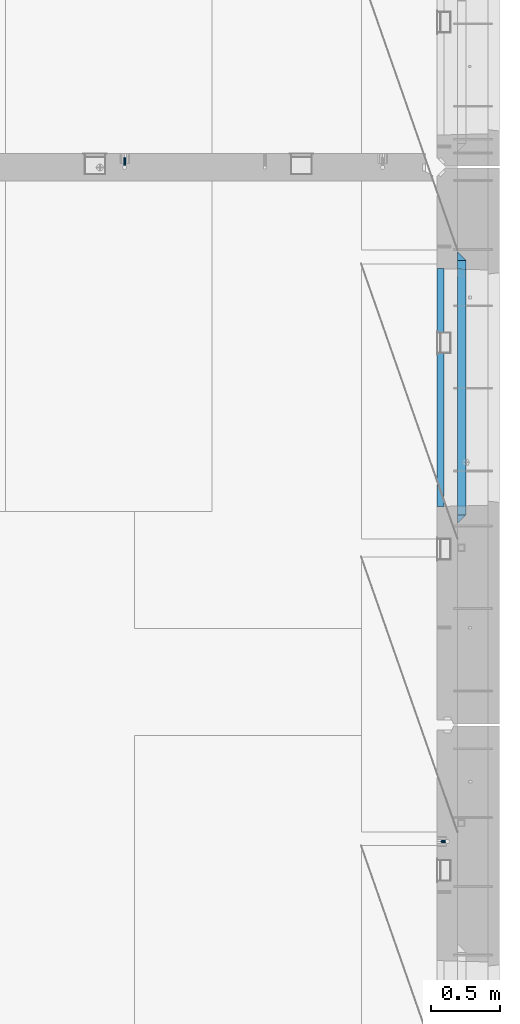
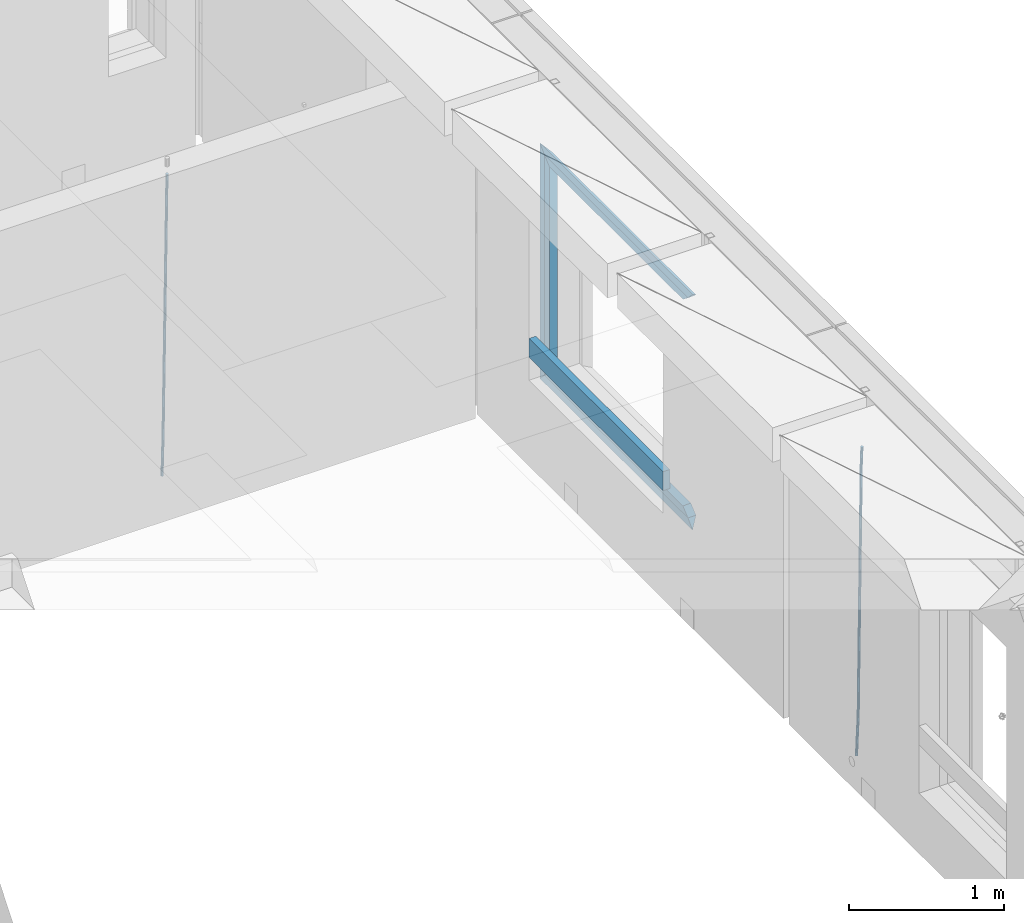
# One storey, part 127 of 341: 9 beams, 3 elements without a shape of their own.
"""IFC2X3 building model written with IfcOpenShell, lengths in millimetres."""

from ifc_helpers import new_model, si_unit, frame, origin_with_axes, place, context, subcontext, project, spatial, faceted_brep, material, type_object, element, aggregate, save


model = new_model("IFC2X3")

# Units and contexts
model_context = context("Model", 3, precision=1e-05, world=origin_with_axes())
body_context = subcontext(model_context, "Body", "Model", "MODEL_VIEW")
ifc_project = project(units=[si_unit("LENGTHUNIT", "METRE", prefix="MILLI"), si_unit("AREAUNIT", "SQUARE_METRE"), si_unit("VOLUMEUNIT", "CUBIC_METRE"), si_unit("MASSUNIT", "GRAM", prefix="KILO"), si_unit("TIMEUNIT", "SECOND"), si_unit("PLANEANGLEUNIT", "RADIAN"), si_unit("SOLIDANGLEUNIT", "STERADIAN"), si_unit("THERMODYNAMICTEMPERATUREUNIT", "DEGREE_CELSIUS"), si_unit("LUMINOUSINTENSITYUNIT", "LUMEN")], contexts=[model_context])

# Site, building, storey
site_placement = place(None, origin_with_axes())
site = spatial("IfcSite", under=ifc_project, at=site_placement, CompositionType="ELEMENT")
building_placement = place(site_placement, origin_with_axes())
building = spatial("IfcBuilding", under=site, at=building_placement, CompositionType="ELEMENT")
storey_placement = place(building_placement, origin_with_axes())
storey = spatial("IfcBuildingStorey", under=building, at=storey_placement, Name="5", CompositionType="ELEMENT", Elevation=0.0)

# Assembly, beam
assembly_1_placement = place(storey_placement, origin_with_axes())
assembly_1 = element("IfcElementAssembly", 1, at=assembly_1_placement, inside=storey, AssemblyPlace="NOTDEFINED", PredefinedType="REINFORCEMENT_UNIT")
ifc_material_1 = material()
beam_type_1 = type_object("IfcBeamType", Name="D20", PredefinedType="NOTDEFINED")
beam_1_placement = place(assembly_1_placement, frame((32639.9999999961, 17044.9997581385, 93990.0), z_axis=(0.00020576299992186, -0.999642804629538, -0.0267249099901004), x_axis=(-4.30000201928125e-08, -0.0267249099948059, 0.999642825806181)))
beam_1 = element("IfcBeam", 2, at=beam_1_placement, type_object=beam_type_1, material=ifc_material_1, Name="JM20", ObjectType="D20", context=body_context, shape_type="Brep", body=[
    faceted_brep([(0.0, -10.0, 0.0), (-4.19531716033816e-08, -7.07106781186667, -7.07106781187031), (60.4266690400545, -7.0710677960451, -7.07106780570757), (60.4266690441291, -9.99999998418934, 6.15546014159918e-09), (0.0, 0.0, -10.0), (60.426669036824, 1.58106558956206e-08, -9.99999999384454), (4.196772351861e-08, 7.07106781186303, -7.07106781186667), (60.4266690363438, 7.07106782768096, -7.07106780570757), (0.0, 10.0, 0.0), (60.4266690388904, 10.0000000158179, 6.15182216279209e-09), (4.196772351861e-08, 7.07106781185939, 7.07106781185939), (60.4266690429649, 7.07106782768096, 7.07106781802577), (0.0, 0.0, 10.0), (60.4266690461809, 1.58179318532348e-08, 10.0000000061555), (-4.19531716033816e-08, -7.07106781187031, 7.07106781185939), (60.4266690466611, -7.07106779605238, 7.07106781802213), (61.0378400410118, -7.07106779588503, -7.07106780564936), (60.991799419251, -9.99999998403655, 6.21366780251265e-09), (61.0569027789461, 1.5985278878361e-08, -9.99999999378269), (61.0378209396877, 7.07106782784831, -7.07106780564936), (60.9917724058905, 10.0000000159635, 6.21366780251265e-09), (60.9457317841297, 7.07106782781193, 7.0710678180767), (60.9266690461809, 1.59488990902901e-08, 10.0000000062028), (60.9457508854539, -7.07106779591413, 7.0710678180767), (61.6489592143771, -7.07106614513759, -7.06310863441468), (61.5568818710308, -9.9999984576425, 0.00735959856683621), (61.6870830769039, 1.71821739058942e-06, -9.99179257185824), (61.6489210170112, 7.07106947854481, -7.06310888312146), (61.556827851804, 10.0000015422847, 0.00735924683976918), (61.4647505084577, 7.07106922979438, 7.07782747982128), (61.4266266459163, 1.36643211590126e-06, 10.0065114172685), (61.464788705809, -7.07106639389531, 7.07782772852806), (176.543135720174, -7.07075579406956, -5.56673531796696), (176.451058376813, -9.99968810657447, 1.50373291501455), (176.581259582701, 0.000312069292704109, -8.49541925541052), (176.543097522794, 7.07137982961285, -5.56673556667374), (176.451004357587, 10.00031189336, 1.50373256329476), (176.35892701424, 7.07137958085514, 8.57420079627263), (176.320803151699, 0.000311717507429421, 11.5028847337162), (176.358965211621, -7.07075604281999, 8.57420104497578), (177.098753836006, -7.07075429323595, -5.55949898843028), (176.98362511232, -9.99968666800123, 1.510669025065), (177.146421932586, 0.000313595905026887, -8.48805862247536), (177.098706077581, 7.07138133041735, -5.55949936166144), (176.983557571715, 10.0003133318824, 1.51066849724157), (176.868428848029, 7.07138095712435, 8.58083651073321), (176.820760751449, 0.000313067976094317, 11.5093961447819), (176.868476606425, -7.07075466652896, 8.58083688396073), (177.654312950661, -7.07075204110879, -5.54863964998367), (177.516135294456, -9.99968450931192, 1.52107783331303), (177.711524267797, 0.000315886711177882, -8.47701274570863), (177.654255632195, 7.07138358250813, -5.54864021007961), (177.516054233929, 10.0003154905207, 1.5210770412159), (177.377876577739, 7.0713830223176, 8.59079452451624), (177.320665260588, 0.000315094497636892, 11.5191676202448), (177.377933896176, -7.07075260129932, 8.59079508461218), (299.499456785634, -7.07025810522464, -3.16697112782276), (299.361279129444, -9.99919057342777, 3.90274635547394), (299.556668102785, 0.000809822595329024, -6.09534422354773), (299.499399467197, 7.07187751838501, -3.1669716879187), (299.361198068917, 10.0008094264049, 3.90274556338045), (299.223020412712, 7.07187695819448, 10.9724630466735), (299.165809095575, 0.000809030381788034, 13.9008361423985), (299.223077731163, -7.07025866542244, 10.9724636067695), (300.03174732349, -7.07025594743027, -3.15656661289177), (299.971788958996, -9.99918809853989, 3.91467979818117), (300.056572611924, 0.000811849109595641, -6.08557274808481), (300.031722507032, 7.07187967631762, -3.15656653768019), (299.971753863239, 10.0008119014747, 3.91467990454839), (299.91179549876, 7.07187975035777, 10.9859263156177), (299.886970210311, 0.000811953817901667, 13.9149324508144), (299.911820315203, -7.0702558733974, 10.9859262404061), (300.564137759997, -7.07025623699155, -3.15794273276697), (300.582413367199, -9.99918843065097, 3.91310145956595), (300.556570941641, 0.000811577163403854, -6.0868651410201), (300.564145451674, 7.07187938674906, -3.15794274158179), (300.582424244858, 10.0008115693345, 3.91310144710224), (300.600699852032, 7.07187937566778, 10.9841456394352), (300.608266670402, 0.000811561512819026, 13.9130680476919), (300.600692160384, -7.07025624805829, 10.98414564825), (2294.16589219622, -7.0713405251372, -8.31099358700158), (2294.1841678034, -10.0002727187966, -1.23994939466866), (2294.15832537785, -0.000272710982244462, -11.2399159952547), (2294.16589988787, 7.07079509858886, -8.31099359582004), (2294.18417868105, 9.99972728118883, -1.23994940713601), (2294.20245428824, 7.07079508752213, 5.83109478519327), (2294.2100211066, -0.00027272663282929, 8.76001719345368), (2294.20244659658, -7.07134053620393, 5.83109479401173), (2294.7782683276, -7.07134085819416, -8.31257645345977), (2294.72126025338, -10.000273010919, -1.24133766827799), (2294.84007459224, -0.000273081772320438, -11.2416781768807), (2294.87047377572, 7.07079471537872, -8.31281477453012), (2294.85165844864, 9.9997269181622, -1.24167470516841), (2294.7946503744, 7.07079476544459, 5.82956408001337), (2294.73284410976, -0.000273010977252852, 8.75866580342336), (2294.7024449263, -7.07134080815013, 5.82980240107645), (2295.39054023061, -7.0793250091956, -8.30442771922026), (2295.25826128852, -10.0072756143927, -1.23419071494573), (2295.52170777075, -0.00916171800054144, -11.2326063125765), (2295.57492774284, 7.06160849139269, -8.30343918807193), (2295.51902460904, 9.99102432676591, -1.23279272078435), (2295.38674566693, 7.06307372157607, 5.83744428349019), (2295.25557812679, -0.0070895696117077, 8.76562287684646), (2295.20235815471, -7.07785977901949, 5.83645575234186), (2317.1947101649, -7.36365585014573, -8.01423575520312), (2317.06243122277, -10.2916064553428, -0.94399875092131), (2317.32587770502, -0.293492558957951, -10.9424143485521), (2317.37909767711, 6.77727765044983, -8.01324722405116), (2317.32319454331, 9.70669348581578, -0.942600756767206), (2317.1909156012, 6.77874288063322, 6.12763624751096), (2317.05974806109, -0.291420410569117, 9.0558148408636), (2317.00652808898, -7.36219061996962, 6.12664771636264), (2317.83015404257, -7.37194216843636, -8.00577862486898), (2317.72252095213, -10.300214160583, -0.935213608652703), (2317.90419832576, -0.301033978277701, -10.9347174723516), (2317.90127966482, 6.77046829039318, -8.00629749759901), (2317.82310777172, 9.70017451494641, -0.935947405505431), (2317.71547468127, 6.77190252279979, 6.13461761071085), (2317.64143039809, -0.29900566735887, 9.06355645819713), (2317.64434905903, -7.37050793602975, 6.13513648344451), (2318.46565174212, -7.3700661537805, -7.99751648408346), (2318.38266643914, -10.2982456018653, -0.926623872735945), (2318.48256818345, -0.299336209594912, -10.9272153854981), (2318.42350634121, 6.77200652527245, -7.99954269419686), (2318.32306384158, 9.70166538090416, -0.929489366557391), (2318.2400785386, 6.77348593281204, 6.14140324480104), (2318.22316209726, -0.297244011366274, 9.07110214621207), (2318.2822239395, -7.36858674623363, 6.1434294549108), (2418.48643733139, -7.07180401323421, -6.70013846199799), (2418.4034520284, -9.99998346132634, 0.370754149349523), (2418.5033537727, -0.00107406904135132, -9.62983736341266), (2418.44429193046, 7.07026866581873, -6.70216467211139), (2418.34384943081, 9.99992752145772, 0.367888655531715), (2418.26086412782, 7.0717480733656, 7.43878126688651), (2418.24394768651, 0.00101812917273492, 10.3684801682975), (2418.30300952874, -7.07032460568735, 7.44080747699627)], [[[0, 1, 2, 3]], [[1, 4, 5, 2]], [[4, 6, 7, 5]], [[6, 8, 9, 7]], [[8, 10, 11, 9]], [[10, 12, 13, 11]], [[12, 14, 15, 13]], [[14, 0, 3, 15]], [[14, 12, 10, 8, 6, 4, 1, 0]], [[3, 2, 16, 17]], [[2, 5, 18, 16]], [[5, 7, 19, 18]], [[7, 9, 20, 19]], [[9, 11, 21, 20]], [[11, 13, 22, 21]], [[13, 15, 23, 22]], [[15, 3, 17, 23]], [[17, 16, 24, 25]], [[16, 18, 26, 24]], [[18, 19, 27, 26]], [[19, 20, 28, 27]], [[20, 21, 29, 28]], [[21, 22, 30, 29]], [[22, 23, 31, 30]], [[23, 17, 25, 31]], [[25, 24, 32, 33]], [[24, 26, 34, 32]], [[26, 27, 35, 34]], [[27, 28, 36, 35]], [[28, 29, 37, 36]], [[29, 30, 38, 37]], [[30, 31, 39, 38]], [[31, 25, 33, 39]], [[33, 32, 40, 41]], [[32, 34, 42, 40]], [[34, 35, 43, 42]], [[35, 36, 44, 43]], [[36, 37, 45, 44]], [[37, 38, 46, 45]], [[38, 39, 47, 46]], [[39, 33, 41, 47]], [[41, 40, 48, 49]], [[40, 42, 50, 48]], [[42, 43, 51, 50]], [[43, 44, 52, 51]], [[44, 45, 53, 52]], [[45, 46, 54, 53]], [[46, 47, 55, 54]], [[47, 41, 49, 55]], [[49, 48, 56, 57]], [[48, 50, 58, 56]], [[50, 51, 59, 58]], [[51, 52, 60, 59]], [[52, 53, 61, 60]], [[53, 54, 62, 61]], [[54, 55, 63, 62]], [[55, 49, 57, 63]], [[57, 56, 64, 65]], [[56, 58, 66, 64]], [[58, 59, 67, 66]], [[59, 60, 68, 67]], [[60, 61, 69, 68]], [[61, 62, 70, 69]], [[62, 63, 71, 70]], [[63, 57, 65, 71]], [[65, 64, 72, 73]], [[64, 66, 74, 72]], [[66, 67, 75, 74]], [[67, 68, 76, 75]], [[68, 69, 77, 76]], [[69, 70, 78, 77]], [[70, 71, 79, 78]], [[71, 65, 73, 79]], [[73, 72, 80, 81]], [[72, 74, 82, 80]], [[74, 75, 83, 82]], [[75, 76, 84, 83]], [[76, 77, 85, 84]], [[77, 78, 86, 85]], [[78, 79, 87, 86]], [[79, 73, 81, 87]], [[81, 80, 88, 89]], [[80, 82, 90, 88]], [[82, 83, 91, 90]], [[83, 84, 92, 91]], [[84, 85, 93, 92]], [[85, 86, 94, 93]], [[86, 87, 95, 94]], [[87, 81, 89, 95]], [[89, 88, 96, 97]], [[88, 90, 98, 96]], [[90, 91, 99, 98]], [[91, 92, 100, 99]], [[92, 93, 101, 100]], [[93, 94, 102, 101]], [[94, 95, 103, 102]], [[95, 89, 97, 103]], [[97, 96, 104, 105]], [[96, 98, 106, 104]], [[98, 99, 107, 106]], [[99, 100, 108, 107]], [[100, 101, 109, 108]], [[101, 102, 110, 109]], [[102, 103, 111, 110]], [[103, 97, 105, 111]], [[105, 104, 112, 113]], [[104, 106, 114, 112]], [[106, 107, 115, 114]], [[107, 108, 116, 115]], [[108, 109, 117, 116]], [[109, 110, 118, 117]], [[110, 111, 119, 118]], [[111, 105, 113, 119]], [[113, 112, 120, 121]], [[112, 114, 122, 120]], [[114, 115, 123, 122]], [[115, 116, 124, 123]], [[116, 117, 125, 124]], [[117, 118, 126, 125]], [[118, 119, 127, 126]], [[119, 113, 121, 127]], [[121, 120, 128, 129]], [[120, 122, 130, 128]], [[122, 123, 131, 130]], [[123, 124, 132, 131]], [[124, 125, 133, 132]], [[125, 126, 134, 133]], [[126, 127, 135, 134]], [[127, 121, 129, 135]], [[130, 131, 132, 133, 134, 135, 129, 128]]]),
])
aggregate(assembly_1, [beam_1])

assembly_2_placement = place(storey_placement, origin_with_axes())
assembly_2 = element("IfcElementAssembly", 3, at=assembly_2_placement, inside=storey, AssemblyPlace="NOTDEFINED", PredefinedType="REINFORCEMENT_UNIT")
beam_2_placement = place(assembly_2_placement, frame((34944.9999977209, 12080.9402860984, 93990.0), z_axis=(0.999642804629538, 0.000205762999925497, -0.0267249099901003), x_axis=(0.0267249109941254, -4.30000210532798e-08, 0.999642825779465)))
beam_2 = element("IfcBeam", 4, at=beam_2_placement, type_object=beam_type_1, material=ifc_material_1, Name="JM20", ObjectType="D20", context=body_context, shape_type="Brep", body=[
    faceted_brep([(0.0, -10.0, 0.0), (-4.19531716033816e-08, -7.07106781186667, -7.07106781187031), (60.4266690400545, -7.0710677960451, -7.07106780570757), (60.4266690441291, -9.99999998418934, 6.15546014159918e-09), (0.0, 0.0, -10.0), (60.426669036824, 1.58106558956206e-08, -9.99999999384454), (4.196772351861e-08, 7.07106781186303, -7.07106781186667), (60.4266690363438, 7.07106782768096, -7.07106780570757), (0.0, 10.0, 0.0), (60.4266690388904, 10.0000000158179, 6.15182216279209e-09), (4.196772351861e-08, 7.07106781185939, 7.07106781185939), (60.4266690429649, 7.07106782768096, 7.07106781802577), (0.0, 0.0, 10.0), (60.4266690461809, 1.58179318532348e-08, 10.0000000061555), (-4.19531716033816e-08, -7.07106781187031, 7.07106781185939), (60.4266690466611, -7.07106779605238, 7.07106781802213), (61.0378400410118, -7.07106779588503, -7.07106780564936), (60.991799419251, -9.99999998403655, 6.21366780251265e-09), (61.0569027789461, 1.5985278878361e-08, -9.99999999378269), (61.0378209396877, 7.07106782784831, -7.07106780564936), (60.9917724058905, 10.0000000159635, 6.21366780251265e-09), (60.9457317841297, 7.07106782781193, 7.0710678180767), (60.9266690461809, 1.59488990902901e-08, 10.0000000062028), (60.9457508854539, -7.07106779591413, 7.0710678180767), (61.6489592143771, -7.07106614513759, -7.06310863441468), (61.5568818710308, -9.9999984576425, 0.00735959856683621), (61.6870830769039, 1.71821739058942e-06, -9.99179257185824), (61.6489210170112, 7.07106947854481, -7.06310888312146), (61.556827851804, 10.0000015422847, 0.00735924683976918), (61.4647505084577, 7.07106922979438, 7.07782747982128), (61.4266266459163, 1.36643211590126e-06, 10.0065114172685), (61.464788705809, -7.07106639389531, 7.07782772852806), (176.543135720174, -7.07075579406956, -5.56673531796696), (176.451058376813, -9.99968810657447, 1.50373291501455), (176.581259582701, 0.000312069292704109, -8.49541925541052), (176.543097522794, 7.07137982961285, -5.56673556667374), (176.451004357587, 10.00031189336, 1.50373256329476), (176.35892701424, 7.07137958085514, 8.57420079627263), (176.320803151699, 0.000311717507429421, 11.5028847337162), (176.358965211621, -7.07075604281999, 8.57420104497578), (177.098753836006, -7.07075429323595, -5.55949898843028), (176.98362511232, -9.99968666800123, 1.510669025065), (177.146421932586, 0.000313595905026887, -8.48805862247536), (177.098706077581, 7.07138133041735, -5.55949936166144), (176.983557571715, 10.0003133318824, 1.51066849724157), (176.868428848029, 7.07138095712435, 8.58083651073321), (176.820760751449, 0.000313067976094317, 11.5093961447819), (176.868476606425, -7.07075466652896, 8.58083688396073), (177.654312950661, -7.07075204110879, -5.54863964998367), (177.516135294456, -9.99968450931192, 1.52107783331303), (177.711524267797, 0.000315886711177882, -8.47701274570863), (177.654255632195, 7.07138358250813, -5.54864021007961), (177.516054233929, 10.0003154905207, 1.5210770412159), (177.377876577739, 7.0713830223176, 8.59079452451624), (177.320665260588, 0.000315094497636892, 11.5191676202448), (177.377933896176, -7.07075260129932, 8.59079508461218), (299.436796249574, -7.07025836271714, -3.1681962331204), (299.298618593355, -9.99919083092027, 3.90152125031091), (299.494007566798, 0.000809565110102994, -6.09656932889993), (299.436738931283, 7.07187726089978, -3.16819679320906), (299.298537533061, 10.0008091689197, 3.90152045822106), (299.160359876842, 7.07187670072017, 10.9712379416487), (299.103148559603, 0.000808772889286047, 13.8996110374392), (299.160417195119, -7.07025892290039, 10.9712385017483), (299.98743051647, -7.07025613056248, -3.15743315966392), (299.971788958996, -9.99918809853989, 3.91467979818117), (299.993912075952, 0.000811591617093654, -6.08679785393178), (299.987423933868, 7.07187949325817, -3.1574327280432), (299.971753863239, 10.0008119014747, 3.91467990454839), (299.95611230444, 7.07187992653053, 10.9867922621015), (299.949630744944, 0.000812204350950196, 13.9161569563694), (299.956118887014, -7.07025569729012, 10.9867918304735), (300.538107039494, -7.07025785017686, -3.16575821840888), (300.644985195438, -9.99919020432935, 3.90450175465594), (300.493854948218, 0.000810030429420294, -6.09435592770024), (300.538151196495, 7.071877773491, -3.16575855385963), (300.645047642858, 10.0008097955724, 3.90450128024895), (300.751925798773, 7.07187744142357, 10.9747612533101), (300.796177890064, 0.000809560813650023, 13.9033589625978), (300.751881641787, -7.07025818224065, 10.9747615887682), (2293.36490490142, -7.07648090940347, -33.2930642912361), (2293.47178305736, -10.0054132635523, -26.2228043181785), (2293.32065281013, -0.00541302880083094, -36.2216620005347), (2293.36494905842, 7.06565471425711, -33.2930646266868), (2293.47184550477, 9.99458673634581, -26.2228047925819), (2293.57872366071, 7.06565438219332, -19.1525448195243), (2293.62297575199, -0.00541349841296324, -16.2239471102366), (2293.57867950371, -7.0764812414709, -19.1525444840736), (2294.0658245362, -7.07648309818615, -33.3036607065333), (2294.05312277409, -10.0054150789219, -26.2315929392535), (2294.10928714235, -0.00541549149056664, -36.2335844756526), (2294.15805078732, 7.06565223761572, -33.3050546393533), (2294.18355038921, 9.99458451388637, -26.2335642579346), (2294.17084862708, 7.06565253314329, -19.1614964906439), (2294.12738602093, -0.00541507354500936, -16.2315727215355), (2294.07862237596, -7.07648280265857, -19.1601025578348), (2294.76670261032, -7.08562269121467, -33.294332712383), (2294.63442802057, -10.0129954178956, -26.2238563411993), (2294.89787471293, -0.0156988342423574, -36.2230891548279), (2294.95110548967, 7.05531064255774, -33.2944998654275), (2294.89521307347, 9.98530428734011, -26.2240927312887), (2294.76293848372, 7.0579315606592, -19.1536163601049), (2294.63176638114, -0.0119922963167483, -16.2248599176673), (2294.57853560438, -7.08300177311321, -19.1534492070678), (2316.52657204497, -7.36937582653991, -33.0047303660212), (2316.39429745522, -10.2967485532172, -25.9342539948302), (2316.65774414754, -0.299451969567599, -35.9334868084661), (2316.7109749243, 6.7715575072325, -33.0048975190657), (2316.65508250811, 9.70155115201487, -25.9344903849269), (2316.52280791836, 6.7741784253376, -18.8640140137468), (2316.39163581574, -0.295745431634714, -15.9352575713092), (2316.33840503903, -7.36675490843481, -18.863846860706), (2317.16202064224, -7.37766220584308, -32.9962731735213), (2317.05438744847, -10.3053562613532, -25.9254688497131), (2317.23607125619, -0.306993473008333, -35.925789846493), (2317.23316144495, 6.76474808850253, -32.9979477328052), (2317.15499573652, 9.6950321815566, -25.9278370341635), (2317.04736254275, 6.7673381260538, -18.8570327103698), (2316.97331192881, -0.303330606784584, -15.9275160373909), (2316.97622174003, -7.37507216829545, -18.8553581510787), (2317.79752306276, -7.37578610372293, -32.9880110666527), (2317.71453320107, -10.3033876998124, -25.9168792378296), (2317.81444760226, -0.305295583297266, -35.918287695793), (2317.75539265381, 6.76628640723357, -32.9911928173897), (2317.65495180529, 9.69652304524061, -25.9213789128698), (2317.5719619436, 6.76892144914746, -18.8502470840467), (2317.55503740412, -0.301569071270933, -15.9199704549137), (2317.61409235255, -7.3731510618054, -18.847065333317), (2417.8183084176, -7.07752398473531, -31.6906369377139), (2417.73531855589, -10.0051255808248, -24.6195051088798), (2417.83523295709, -0.007033464313281, -34.6209135668432), (2417.77617800863, 7.06454852621755, -31.6938186884508), (2417.67573716014, 9.99478516423187, -24.6240047839383), (2417.59274729842, 7.06718356813872, -17.5528729551006), (2417.57582275895, -0.00330695228694822, -14.6225963259749), (2417.6348777074, -7.07488894281778, -17.5496912043673)], [[[0, 1, 2, 3]], [[1, 4, 5, 2]], [[4, 6, 7, 5]], [[6, 8, 9, 7]], [[8, 10, 11, 9]], [[10, 12, 13, 11]], [[12, 14, 15, 13]], [[14, 0, 3, 15]], [[14, 12, 10, 8, 6, 4, 1, 0]], [[3, 2, 16, 17]], [[2, 5, 18, 16]], [[5, 7, 19, 18]], [[7, 9, 20, 19]], [[9, 11, 21, 20]], [[11, 13, 22, 21]], [[13, 15, 23, 22]], [[15, 3, 17, 23]], [[17, 16, 24, 25]], [[16, 18, 26, 24]], [[18, 19, 27, 26]], [[19, 20, 28, 27]], [[20, 21, 29, 28]], [[21, 22, 30, 29]], [[22, 23, 31, 30]], [[23, 17, 25, 31]], [[25, 24, 32, 33]], [[24, 26, 34, 32]], [[26, 27, 35, 34]], [[27, 28, 36, 35]], [[28, 29, 37, 36]], [[29, 30, 38, 37]], [[30, 31, 39, 38]], [[31, 25, 33, 39]], [[33, 32, 40, 41]], [[32, 34, 42, 40]], [[34, 35, 43, 42]], [[35, 36, 44, 43]], [[36, 37, 45, 44]], [[37, 38, 46, 45]], [[38, 39, 47, 46]], [[39, 33, 41, 47]], [[41, 40, 48, 49]], [[40, 42, 50, 48]], [[42, 43, 51, 50]], [[43, 44, 52, 51]], [[44, 45, 53, 52]], [[45, 46, 54, 53]], [[46, 47, 55, 54]], [[47, 41, 49, 55]], [[49, 48, 56, 57]], [[48, 50, 58, 56]], [[50, 51, 59, 58]], [[51, 52, 60, 59]], [[52, 53, 61, 60]], [[53, 54, 62, 61]], [[54, 55, 63, 62]], [[55, 49, 57, 63]], [[57, 56, 64, 65]], [[56, 58, 66, 64]], [[58, 59, 67, 66]], [[59, 60, 68, 67]], [[60, 61, 69, 68]], [[61, 62, 70, 69]], [[62, 63, 71, 70]], [[63, 57, 65, 71]], [[65, 64, 72, 73]], [[64, 66, 74, 72]], [[66, 67, 75, 74]], [[67, 68, 76, 75]], [[68, 69, 77, 76]], [[69, 70, 78, 77]], [[70, 71, 79, 78]], [[71, 65, 73, 79]], [[73, 72, 80, 81]], [[72, 74, 82, 80]], [[74, 75, 83, 82]], [[75, 76, 84, 83]], [[76, 77, 85, 84]], [[77, 78, 86, 85]], [[78, 79, 87, 86]], [[79, 73, 81, 87]], [[81, 80, 88, 89]], [[80, 82, 90, 88]], [[82, 83, 91, 90]], [[83, 84, 92, 91]], [[84, 85, 93, 92]], [[85, 86, 94, 93]], [[86, 87, 95, 94]], [[87, 81, 89, 95]], [[89, 88, 96, 97]], [[88, 90, 98, 96]], [[90, 91, 99, 98]], [[91, 92, 100, 99]], [[92, 93, 101, 100]], [[93, 94, 102, 101]], [[94, 95, 103, 102]], [[95, 89, 97, 103]], [[97, 96, 104, 105]], [[96, 98, 106, 104]], [[98, 99, 107, 106]], [[99, 100, 108, 107]], [[100, 101, 109, 108]], [[101, 102, 110, 109]], [[102, 103, 111, 110]], [[103, 97, 105, 111]], [[105, 104, 112, 113]], [[104, 106, 114, 112]], [[106, 107, 115, 114]], [[107, 108, 116, 115]], [[108, 109, 117, 116]], [[109, 110, 118, 117]], [[110, 111, 119, 118]], [[111, 105, 113, 119]], [[113, 112, 120, 121]], [[112, 114, 122, 120]], [[114, 115, 123, 122]], [[115, 116, 124, 123]], [[116, 117, 125, 124]], [[117, 118, 126, 125]], [[118, 119, 127, 126]], [[119, 113, 121, 127]], [[121, 120, 128, 129]], [[120, 122, 130, 128]], [[122, 123, 131, 130]], [[123, 124, 132, 131]], [[124, 125, 133, 132]], [[125, 126, 134, 133]], [[126, 127, 135, 134]], [[127, 121, 129, 135]], [[130, 131, 132, 133, 134, 135, 129, 128]]]),
])
aggregate(assembly_2, [beam_2])

# Assembly, beams
assembly_3_placement = place(storey_placement, origin_with_axes())
assembly_3 = element("IfcElementAssembly", 5, at=assembly_3_placement, inside=storey, AssemblyPlace="NOTDEFINED", PredefinedType="REINFORCEMENT_UNIT")
ifc_material_2 = material(Name="TIMBER/T24")
beam_type_2 = type_object("IfcBeamType", PredefinedType="NOTDEFINED")
beam_3_placement = place(assembly_3_placement, frame((34935.0002758707, 14515.0011884524, 94685.0), z_axis=(0.0, 0.0, 1.0), x_axis=(0.0, 1.0, 0.0)))
beam_3 = element("IfcBeam", 6, at=beam_3_placement, type_object=beam_type_2, material=ifc_material_2, context=body_context, shape_type="Brep", body=[
    faceted_brep([(-3.63797880709171e-12, 24.9999999999964, -75.0), (-3.63797880709171e-12, 24.9999999999964, 75.0), (1730.0, 25.0, 75.0), (1730.0, 25.0, -75.0), (0.0, -25.0000000000073, 75.0), (1730.0, -25.0, 75.0), (0.0, -25.0000000000073, -75.0), (1730.0, -25.0, -75.0)], [[[0, 1, 2, 3]], [[1, 4, 5, 2]], [[4, 6, 7, 5]], [[6, 0, 3, 7]], [[5, 7, 3, 2]], [[6, 4, 1, 0]]]),
])
ifc_material_3 = material(Name="CONCRETE/C25/30")
beam_type_3 = type_object("IfcBeamType", PredefinedType="NOTDEFINED")
beam_4_placement = place(assembly_3_placement, frame((35090.0, 14394.9995850056, 96145.0), z_axis=(0.0, 0.0, -1.0), x_axis=(0.0, 1.0, 0.0)))
beam_4 = element("IfcBeam", 7, at=beam_4_placement, type_object=beam_type_3, material=ifc_material_3, Name="SK", context=body_context, shape_type="Brep", body=[
    faceted_brep([(60.0000000000073, 30.0, 30.0), (0.0, -30.0, -30.0), (60.0000000000073, -30.0, 30.0), (1910.00076293945, 30.0, 30.0), (1970.00076293945, -30.0, -30.0), (1910.00076293945, -30.0, 30.0)], [[[0, 1, 2]], [[1, 0, 3, 4]], [[2, 1, 4, 5]], [[0, 2, 5, 3]], [[4, 3, 5]]]),
])
beam_5_placement = place(assembly_3_placement, frame((35090.0, 14454.9995850056, 96085.0), z_axis=(0.0, 0.0, -1.0), x_axis=(0.0, 1.0, 0.0)))
beam_5 = element("IfcBeam", 8, at=beam_5_placement, type_object=beam_type_3, material=ifc_material_3, Name="SK", context=body_context, shape_type="Brep", body=[
    faceted_brep([(1785.9467088854, -30.0, 24.0540540540533), (1784.32508726378, 30.0, 25.6756756756804), (65.6764386151262, 30.0, 25.6756756756804), (64.0548169935064, -30.0, 24.0540540540533), (65.6764386151262, 30.0, 26.294090229203), (64.0548169935064, -30.0, 24.9041288395529), (0.0, 30.0, -30.0), (0.0, -30.0, -30.0), (1850.00076293945, 30.0, -30.0), (1850.00076293945, -30.0, -30.0), (1785.9467088854, -30.0, 24.9034748914128), (1784.32508726378, 30.0, 26.2934362810774)], [[[0, 1, 2, 3]], [[3, 2, 4, 5]], [[5, 4, 6, 7]], [[7, 6, 8, 9]], [[0, 3, 5, 7, 9, 10]], [[1, 0, 10, 11]], [[6, 4, 2, 1, 11, 8]], [[9, 8, 11, 10]]]),
])
beam_6_placement = place(assembly_3_placement, frame((35090.0, 16335.0003479451, 96175.0), z_axis=(0.0, -1.0, 0.0), x_axis=(0.0, 0.0, -1.0)))
beam_6 = element("IfcBeam", 9, at=beam_6_placement, type_object=beam_type_3, material=ifc_material_3, Name="SK", context=body_context, shape_type="Brep", body=[
    faceted_brep([(60.0000000000073, 30.0, 30.0), (0.0, -30.0, -30.0), (60.0000000000073, -30.0, 30.0), (1795.00000000001, 30.0, 30.0), (1855.0, -30.0, -30.0), (1795.00000000001, -30.0, 30.0)], [[[0, 1, 2]], [[3, 4, 1, 0]], [[4, 5, 2, 1]], [[5, 3, 0, 2]], [[5, 4, 3]]]),
])
beam_7_placement = place(assembly_3_placement, frame((35090.0, 16305.0003479451, 94410.0), z_axis=(0.0, 0.0, 1.0), x_axis=(0.0, -1.0, 0.0)))
beam_7 = element("IfcBeam", 10, at=beam_7_placement, type_object=beam_type_3, material=ifc_material_3, Name="SK", context=body_context, shape_type="Brep", body=[
    faceted_brep([(1785.94594594595, -30.0, 24.0540540540533), (1784.32432432433, 30.0, 25.6756756756804), (65.6756756756768, 30.0, 25.6756756756804), (64.0540540540533, -30.0, 24.0540540540533), (1785.94594594595, -30.0, 24.9041288395238), (1784.32432432433, 30.0, 26.2940902291739), (1850.00076293945, -30.0, -30.0), (1850.00076293945, 30.0, -30.0), (0.0, 30.0, -30.0), (65.6756756756768, 30.0, 26.293436281092), (64.0540540540533, -30.0, 24.9034748914419), (0.0, -30.0, -30.0)], [[[0, 1, 2, 3]], [[1, 0, 4, 5]], [[4, 6, 7, 5]], [[2, 1, 5, 7, 8, 9]], [[3, 2, 9, 10]], [[6, 4, 0, 3, 10, 11]], [[11, 8, 7, 6]], [[11, 10, 9, 8]]]),
])
beam_8_placement = place(assembly_3_placement, frame((35090.0, 16365.0003479451, 94350.0), z_axis=(0.0, 0.0, 1.0), x_axis=(0.0, -1.0, 0.0)))
beam_8 = element("IfcBeam", 11, at=beam_8_placement, type_object=beam_type_3, material=ifc_material_3, Name="SK", context=body_context, shape_type="Brep", body=[
    faceted_brep([(1970.00076293945, -30.0, -30.0), (1910.00076293945, 30.0, 30.0), (1910.00076293945, -30.0, 30.0), (60.0000000000073, 30.0, 30.0), (60.0000000000073, -30.0, 30.0), (0.0, -30.0, -30.0)], [[[0, 1, 2]], [[3, 4, 2, 1]], [[4, 5, 0, 2]], [[5, 3, 1, 0]], [[3, 5, 4]]]),
])
beam_type_4 = type_object("IfcBeamType", PredefinedType="NOTDEFINED")
beam_9_placement = place(assembly_3_placement, frame((35090.0, 16270.0003479451, 96115.0), z_axis=(0.0, -1.0, 0.0), x_axis=(0.0, 0.0, -1.0)))
beam_9 = element("IfcBeam", 12, at=beam_9_placement, type_object=beam_type_4, material=ifc_material_3, Name="SK", context=body_context, shape_type="Brep", body=[
    faceted_brep([(0.0, -30.0, -35.0), (54.9034748914273, -30.0, 29.0540540540533), (56.2934362811066, 30.0, 30.6756756756768), (0.0, 30.0, -35.0), (1735.0, 30.0, -35.0), (1735.0, -30.0, -35.0), (1680.09652510857, -30.0, 29.0540540540533), (1678.70656371891, 30.0, 30.6756756756768)], [[[0, 1, 2, 3]], [[4, 5, 0, 3]], [[1, 0, 5, 6]], [[2, 1, 6, 7]], [[3, 2, 7, 4]], [[5, 4, 7, 6]]]),
])
aggregate(assembly_3, [beam_3, beam_4, beam_5, beam_6, beam_9, beam_7, beam_8])

save(model, "model.ifc")
